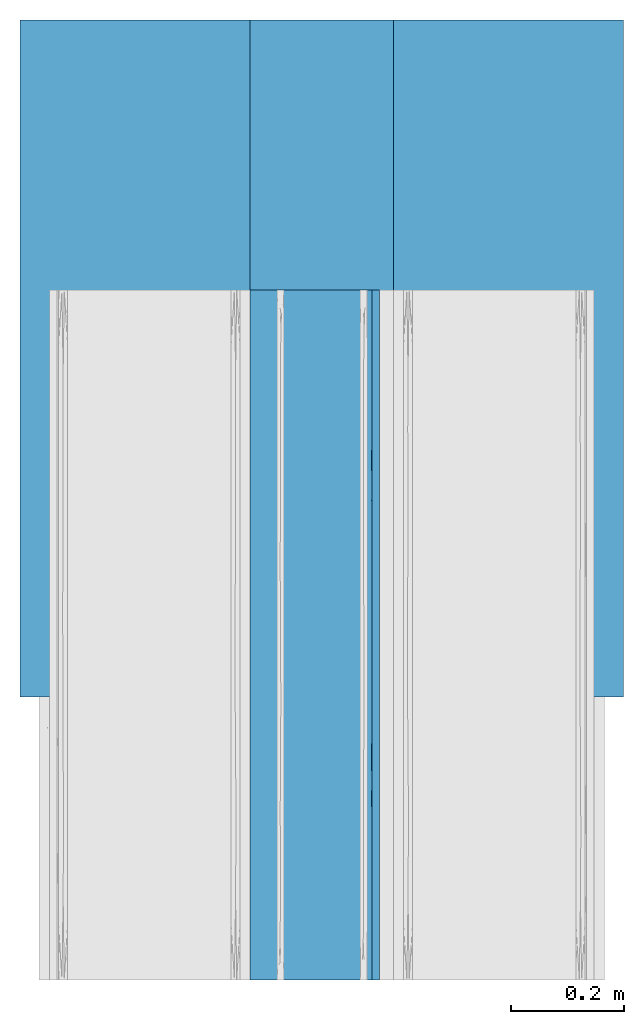
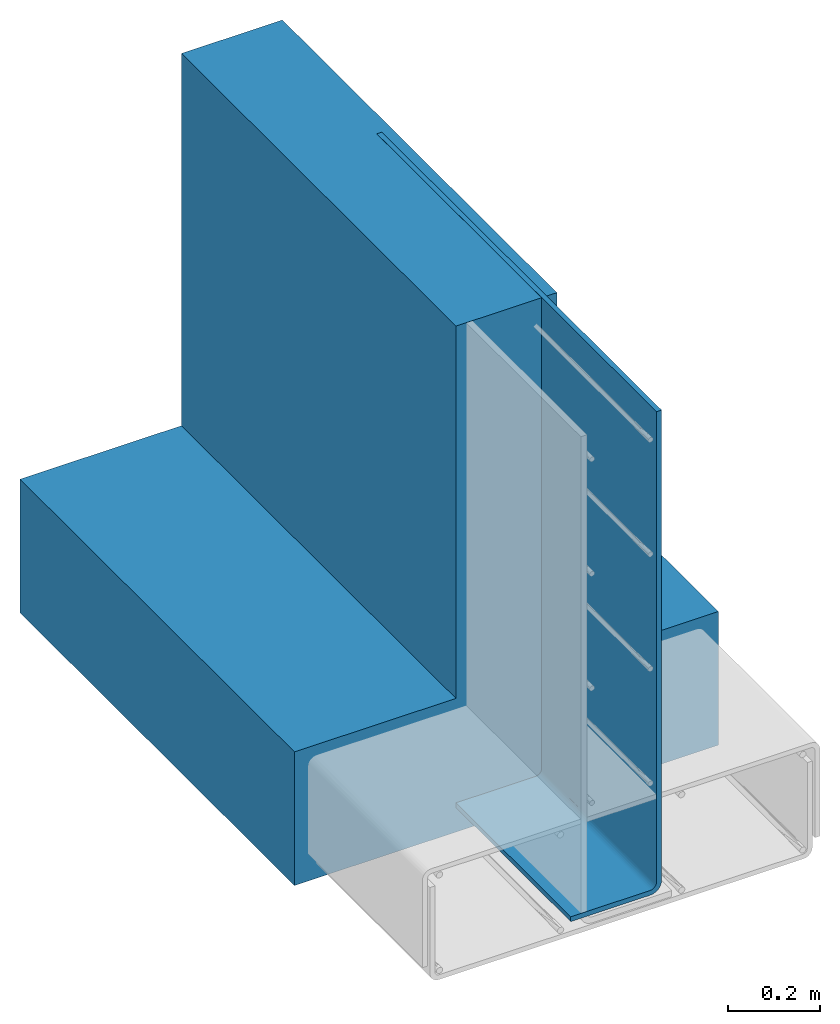
# One storey, part 1 of 10: 2 walls.
"""IFC2X3 building model written with IfcOpenShell, lengths in feet."""

from ifc_helpers import new_model, entity, si_unit, converted_unit, derived_unit, direction, frame, origin, place, context, subcontext, project, spatial, faceted_brep, material, type_object, element, save


model = new_model("IFC2X3")

# Units and contexts
model_context = context("Model", 3, precision=0.0001, world=origin(), true_north=direction((6.12303176911189e-17, 1.0)))
body_context = subcontext(model_context, "Body", "Model", "MODEL_VIEW")
ifc_project = project(units=[converted_unit("LENGTHUNIT", "FOOT", entity("IfcRatioMeasure", 0.3048), si_unit("LENGTHUNIT", "METRE"), dimensions=[1, 0, 0, 0, 0, 0, 0]), converted_unit("AREAUNIT", "SQUARE FOOT", entity("IfcRatioMeasure", 0.09290304), si_unit("AREAUNIT", "SQUARE_METRE"), dimensions=[2, 0, 0, 0, 0, 0, 0]), converted_unit("VOLUMEUNIT", "CUBIC FOOT", entity("IfcRatioMeasure", 0.028316846592), si_unit("VOLUMEUNIT", "CUBIC_METRE"), dimensions=[3, 0, 0, 0, 0, 0, 0]), converted_unit("PLANEANGLEUNIT", "DEGREE", entity("IfcRatioMeasure", 0.0174532925199433), si_unit("PLANEANGLEUNIT", "RADIAN"), dimensions=[0, 0, 0, 0, 0, 0, 0]), si_unit("MASSUNIT", "GRAM", prefix="KILO"), derived_unit("MASSDENSITYUNIT", [(si_unit("MASSUNIT", "GRAM", prefix="KILO"), 1), (si_unit("LENGTHUNIT", "METRE"), -3)]), si_unit("TIMEUNIT", "SECOND"), si_unit("FREQUENCYUNIT", "HERTZ"), si_unit("THERMODYNAMICTEMPERATUREUNIT", "DEGREE_CELSIUS"), derived_unit("THERMALTRANSMITTANCEUNIT", [(si_unit("MASSUNIT", "GRAM", prefix="KILO"), 1), (si_unit("THERMODYNAMICTEMPERATUREUNIT", "KELVIN"), -1), (si_unit("TIMEUNIT", "SECOND"), -3)]), derived_unit("VOLUMETRICFLOWRATEUNIT", [(si_unit("LENGTHUNIT", "METRE"), 3), (si_unit("TIMEUNIT", "SECOND"), -1)]), si_unit("ELECTRICCURRENTUNIT", "AMPERE"), si_unit("ELECTRICVOLTAGEUNIT", "VOLT"), si_unit("POWERUNIT", "WATT"), si_unit("FORCEUNIT", "NEWTON", prefix="KILO"), si_unit("ILLUMINANCEUNIT", "LUX"), si_unit("LUMINOUSFLUXUNIT", "LUMEN"), si_unit("LUMINOUSINTENSITYUNIT", "CANDELA"), derived_unit("USERDEFINED", [(si_unit("MASSUNIT", "GRAM", prefix="KILO"), -1), (si_unit("LENGTHUNIT", "METRE"), -2), (si_unit("TIMEUNIT", "SECOND"), 3), (si_unit("LUMINOUSFLUXUNIT", "LUMEN"), 1)]), derived_unit("LINEARVELOCITYUNIT", [(si_unit("LENGTHUNIT", "METRE"), 1), (si_unit("TIMEUNIT", "SECOND"), -1)]), si_unit("PRESSUREUNIT", "PASCAL"), derived_unit("USERDEFINED", [(si_unit("LENGTHUNIT", "METRE"), -2), (si_unit("MASSUNIT", "GRAM", prefix="KILO"), 1), (si_unit("TIMEUNIT", "SECOND"), -2)])], contexts=[model_context])

# Site, building, storey
site_placement = place(None, origin())
site = spatial("IfcSite", under=ifc_project, at=site_placement, CompositionType="ELEMENT")
building_placement = place(site_placement, origin())
building = spatial("IfcBuilding", under=site, at=building_placement, CompositionType="ELEMENT")
storey_placement = place(building_placement, frame((0.0, 0.0, 11.2604166666667)))
storey = spatial("IfcBuildingStorey", under=building, at=storey_placement, Name="2ND FLOOR", CompositionType="ELEMENT", Elevation=11.2604166666667)

# Walls
ifc_material_1 = material()
wall_type_1 = type_object("IfcWallType", Name="Generic Models 1", PredefinedType="NOTDEFINED", material=ifc_material_1)
wall_1_placement = place(storey_placement, frame((1427.92878869988, 1.89104784498346, 2.73836674408173), z_axis=(0.0, 0.0, 1.0), x_axis=(0.0, 1.0, 0.0)))
element("IfcWall", 1, at=wall_1_placement, inside=storey, type_object=wall_type_1, material=ifc_material_1, Name="Generic Models 42:Generic Models 1", ObjectType="Generic Models 42:Generic Models 1", context=body_context, shape_type="Brep", body=[
    faceted_brep([(3.92583335960777, -2.16666666666674, 1.16666666666667), (3.92583335960776, -3.5, 1.16666666666667), (3.92583335960776, -3.5, 0.0), (3.92583335960777, 0.0, 0.0), (3.92583335960777, 0.0, 1.16666666666668), (3.92583335960777, -1.33333333333326, 1.16666666666668), (3.92583335960778, -1.33333333333326, 4.41666666666668), (3.92583335960777, -2.16666666666674, 4.41666666666667), (0.0, -2.16666666666674, 1.16666666666668), (0.0, -2.16666666666674, 4.41666666666668), (0.0, -1.33333333333326, 4.41666666666669), (0.0, -1.33333333333326, 1.16666666666668), (0.0, 0.0, 1.16666666666669), (0.0, 0.0, 0.0), (0.0, -3.5, 0.0), (0.0, -3.5, 1.16666666666668)], [[[0, 1, 2, 3, 4, 5, 6, 7]], [[8, 9, 10, 11, 12, 13, 14, 15]], [[13, 12, 4, 3]], [[14, 13, 3, 2]], [[15, 14, 2, 1]], [[8, 15, 1, 0]], [[9, 8, 0, 7]], [[10, 9, 7, 6]], [[11, 10, 6, 5]], [[12, 11, 5, 4]]]),
])
ifc_material_2 = material()
wall_type_2 = type_object("IfcWallType", Name="Generic Models 1", PredefinedType="NOTDEFINED", material=ifc_material_2)
wall_2_placement = place(storey_placement, frame((1429.26212203322, 0.249999999995818, 2.95190841074831), z_axis=(0.0, 0.0, 1.0), x_axis=(0.0, 1.0, 0.0)))
element("IfcWall", 2, at=wall_2_placement, inside=storey, type_object=wall_type_2, material=ifc_material_2, Name="Generic Models 45:Generic Models 1", ObjectType="Generic Models 45:Generic Models 1", context=body_context, shape_type="Brep", body=[
    faceted_brep([(4.0, -0.654940473948045, 0.0), (4.0, 0.0, 0.0), (4.0, 0.0, 0.0416666666663001), (4.0, -0.654940473948045, 0.0416666666668739), (4.0, -0.668759562829564, 0.0434859842324968), (4.0, -0.681636903640765, 0.0488199534438305), (4.0, -0.692694926886361, 0.0573050731139269), (4.0, -0.701180046556601, 0.0683630963595885), (4.0, -0.70651401576788, 0.081240437170873), (4.0, -0.70833333333394, 0.0950595260523031), (4.0, -0.70833333333394, 4.2031250000001), (4.0, -0.750000000000227, 4.2031250000001), (4.0, -0.750000000000227, 0.0950595260523031), (4.0, -0.746760925196668, 0.0704563102916005), (4.0, -0.737264438380862, 0.0475297630262546), (4.0, -0.722157709435805, 0.027842290564486), (4.0, -0.702470236974023, 0.0127355616194791), (4.0, -0.67954368970868, 0.00323907480378516), (0.0, -0.70651401576788, 0.0812404371708659), (0.0, -0.701180046556601, 0.0683630963595814), (0.0, -0.692694926886361, 0.0573050731139197), (0.0, -0.681636903640765, 0.0488199534438234), (0.0, -0.668759562829564, 0.0434859842324897), (0.0, -0.654940473948045, 0.0416666666668668), (0.0, 0.0, 0.041666666666293), (0.0, 0.0, 0.0), (0.0, -0.654940473948045, 0.0), (0.0, -0.67954368970868, 0.00323907480377805), (0.0, -0.702470236974023, 0.012735561619472), (0.0, -0.722157709435805, 0.0278422905644788), (0.0, -0.737264438380862, 0.0475297630262475), (0.0, -0.746760925196668, 0.0704563102915934), (0.0, -0.750000000000227, 0.095059526052296), (0.0, -0.750000000000227, 4.20312500000009), (0.0, -0.70833333333394, 4.20312500000009), (0.0, -0.708333333333485, 0.095059526052296), (3.53786209601163, -0.708333333333485, 0.0950595260523031), (3.07572419202325, -0.708333333333485, 0.0950595260523013), (2.76893104800582, -0.708333333333485, 0.0950595260522995), (2.46213790398839, -0.708333333333485, 0.0950595260522995), (2.15534475997096, -0.708333333333485, 0.0950595260522995), (1.84855161595353, -0.708333333333485, 0.0950595260522995), (1.38641371196515, -0.708333333333485, 0.0950595260522995), (0.924275807976768, -0.708333333333485, 0.0950595260522977), (0.462137903988388, -0.708333333333485, 0.095059526052296), (0.616639049233824, -0.750000000000227, 0.0950595260522977), (1.23327809846764, -0.750000000000227, 0.0950595260522995), (1.84991714770146, -0.750000000000227, 0.0950595260522995), (2.46654337646354, -0.750000000000227, 0.0950595260522995), (3.23327168823178, -0.750000000000455, 0.0950595260523031), (3.50726805026566, -0.742764024438657, 0.0586818203459991), (3.27393777489857, -0.730356266470153, 0.0371909531347612), (1.78353021485442, -0.692743608241926, 0.00784005270600829), (2.14117387155801, -0.712809046871143, 0.0196437335345188), (1.43361804815222, -0.710409011264119, 0.0178613728279355), (3.37133042403174, -0.712809046871371, 0.0196437335345596), (3.47516629155208, -0.684714342549569, 0.00478311583486857), (1.16066371901762, -0.730356266491071, 0.0371909531619252), (1.64315400937903, -0.736469617346074, 0.0461789340957903), (1.27449515241569, -0.744572591547922, 0.0633988724297367), (3.20256950663317, -0.747872964695944, 0.0750628849187933), (0.766726281502993, -0.654940473948045, 0.0), (3.38336486871777, -0.654940473948045, 0.0), (2.76672973743553, -0.654940473948045, 0.0), (3.0750482505511, -0.672165363612976, 0.00157360909534354), (2.27636655078764, -0.677207509047321, 0.00264474021617644), (1.53345947487106, -0.654940473948045, 0.0), (0.914458128687511, -0.673697549752205, 0.0018689385419588), (0.924951748600551, -0.748367007938896, 0.0775154033977543), (2.89787096288552, -0.742764024439339, 0.0586818203472532), (0.726062224985724, -0.712809046889788, 0.0196437335487509), (1.47536976770805, -0.675630905083608, 0.00227903482341141), (2.1500946061533, -0.654940473948045, 0.0), (0.524941123283752, -0.730356266478793, 0.0371909531461316), (0.523544479078734, -0.688260808434279, 0.00603105418525907), (2.75625214777426, -0.710886029197582, 0.0182063651474849), (2.46098355502067, -0.731003860446435, 0.0380448373515279), (2.96682787454796, -0.691318179661494, 0.00723597556452482), (0.74650406804044, -0.742764024446615, 0.0586818203647752), (1.72599254344286, -0.724628522043304, 0.0304074615384167), (2.61939838620574, -0.747999034295844, 0.07565803540761), (1.82218751553688, -0.744542946883485, 0.0633150724093436), (1.10212903734058, -0.691318179697419, 0.00723597557942668), (2.37080233363285, -0.696497835331684, 0.00956508641982445), (2.35548845498682, -0.743252101924099, 0.0598832576675505), (0.462137772483759, -0.654940473948045, 0.0416666666668686), (0.924275704597117, -0.654940473948045, 0.0416666666668686), (1.38641363671048, -0.654940473948045, 0.0416666666668704), (1.84855156882383, -0.654940473948045, 0.0416666666668704), (2.1553446706538, -0.654940473948045, 0.0416666666668721), (2.46213793211337, -0.654940473948045, 0.0416666666668704), (2.76893119357294, -0.654940473948045, 0.0416666666668704), (3.0757242954029, -0.654940473948045, 0.0416666666668721), (3.53786222751626, -0.654940473948045, 0.0416666666668721), (3.64598811712504, -0.697299877144587, 0.0625560124856221), (1.94218582917246, -0.689093412479906, 0.0540183976201511), (1.7844557448637, -0.700799087499718, 0.067713868326214), (2.09940456529272, -0.699184866415408, 0.0651725528274447), (1.47460447533869, -0.702533590570511, 0.0708584375743069), (1.15534474637238, -0.705782492088247, 0.0787534957325668), (1.48739929718563, -0.706737282250288, 0.08210236266466), (0.63769039670443, -0.704269043902059, 0.0746269633239951), (0.414263127907032, -0.697299877262594, 0.0625560126393534), (0.287039221922981, -0.704269043910244, 0.0746269633438672), (3.58573686408363, -0.687443987216056, 0.0527001226265824), (0.46236480933283, -0.70712805056678, 0.0837788221728459), (3.36230959219967, -0.675373036542624, 0.0457309560429078), (2.91027129403529, -0.67529423467704, 0.0456983889347438), (3.1442828206046, -0.686932031455399, 0.052312155588119), (3.20329566014424, -0.665610566004943, 0.0427436912711396), (3.53763518372118, -0.666221177726129, 0.0428719494116319), (1.06747187120828, -0.686899893475356, 0.0522881227923335), (0.87330765656503, -0.675612061593483, 0.0458306432946163), (0.645037423284104, -0.687443987251754, 0.0527001226538975), (0.80093383662545, -0.698311267812414, 0.0639183688334466), (2.22079103365052, -0.688777997513398, 0.0537579591047699), (2.6833144259933, -0.689272242176457, 0.054167875025934), (2.46213789152936, -0.677182288721951, 0.0465198607370549), (0.29107500763931, -0.687443987293818, 0.0527001226862005), (3.6466666164122, -0.707137317158413, 0.0838217775129948), (3.75381505076288, -0.70409496819002, 0.0742116693479389), (3.71296077324106, -0.675373036583323, 0.0457309560597405), (3.32859635224714, -0.699184284103694, 0.0651716907968005), (2.9074547776396, -0.664096162172882, 0.0424575222265879), (2.6155344681911, -0.666323046289108, 0.0428940731140681), (0.796704327672058, -0.707256308704473, 0.0843894338746161), (0.416849823803879, -0.675373036577412, 0.0457309560573353), (2.60225741992453, -0.704500195142373, 0.0751941927176265), (2.31326743691376, -0.70586224472504, 0.0790042872096333), (2.61553444643094, -0.707492782959434, 0.0856227760337589), (1.32784821439839, -0.676962339802003, 0.0464196775979406), (3.30679310827372, -0.707491903927348, 0.0856178821016425), (3.14757123404816, -0.703347670118546, 0.0725308600405103), (2.89992805880822, -0.705601455777924, 0.0781994443978817), (0.3104121269, -0.665027413329653, 0.0426281319523643), (1.12933184833539, -0.666136511478271, 0.0428537200823094), (0.811192008238723, -0.66523545261748, 0.0426685836333291), (2.1621734149421, -0.679919010069852, 0.0478698008298988), (3.44406569779068, -0.704269043676504, 0.0746269627796643), (2.56192795606219, -0.699541086891259, 0.0657067960525985), (1.81115138144312, -0.705519689828634, 0.0779557149492121), (3.01120459260311, -0.697299877075011, 0.0625560123948858), (2.20626680044722, -0.665951770188258, 0.04281444218344), (1.18760454552437, -0.697299877202568, 0.0625560125612346), (1.75986133782446, -0.683162484460354, 0.0497349680732277), (1.67497245290147, -0.691173304635186, 0.0558424454146014), (1.47980629766405, -0.666577214964946, 0.0429501824385063), (1.9111713378428, -0.664941043478848, 0.0426115895589483), (1.3955252457092, -0.6865651152998, 0.0520400014997673), (1.60857290622061, -0.675061831460653, 0.0456031977898874), (1.89543238866513, -0.674789727278949, 0.045493362436817), (1.55304368584786, -0.697352793377604, 0.0626250907410135)], [[[0, 1, 2, 3, 4, 5, 6, 7, 8, 9, 10, 11, 12, 13, 14, 15, 16, 17]], [[18, 19, 20, 21, 22, 23, 24, 25, 26, 27, 28, 29, 30, 31, 32, 33, 34, 35]], [[35, 34, 10, 9, 36, 37, 38, 39, 40, 41, 42, 43, 44]], [[34, 33, 11, 10]], [[33, 32, 45, 46, 47, 48, 49, 12, 11]], [[50, 51, 14]], [[52, 53, 54]], [[14, 51, 15]], [[14, 13, 50]], [[55, 16, 15]], [[16, 55, 56]], [[57, 58, 59]], [[49, 60, 12]], [[27, 26, 61]], [[62, 0, 17]], [[63, 64, 65]], [[66, 67, 61]], [[31, 68, 45]], [[60, 69, 50]], [[54, 57, 70]], [[71, 72, 65]], [[29, 73, 30]], [[70, 28, 74]], [[53, 75, 76]], [[64, 56, 77]], [[68, 31, 78]], [[30, 73, 78]], [[55, 15, 51]], [[30, 78, 31]], [[67, 74, 27]], [[59, 46, 68]], [[28, 70, 29]], [[79, 57, 54]], [[62, 64, 63]], [[80, 69, 60]], [[81, 47, 59]], [[54, 70, 82]], [[67, 66, 71]], [[73, 70, 57]], [[76, 51, 69]], [[49, 80, 60]], [[53, 83, 75]], [[80, 84, 69]], [[79, 58, 57]], [[51, 76, 75]], [[56, 55, 77]], [[45, 68, 46]], [[45, 32, 31]], [[59, 68, 78]], [[56, 62, 17]], [[65, 64, 77]], [[52, 83, 53]], [[65, 52, 71]], [[62, 56, 64]], [[16, 56, 17]], [[57, 59, 78]], [[80, 47, 81]], [[70, 73, 29]], [[78, 73, 57]], [[51, 50, 69]], [[52, 54, 82]], [[54, 53, 79]], [[71, 52, 82]], [[52, 65, 83]], [[71, 82, 67]], [[74, 67, 82]], [[27, 61, 67]], [[70, 74, 82]], [[28, 27, 74]], [[65, 77, 83]], [[75, 77, 55]], [[77, 75, 83]], [[75, 55, 51]], [[53, 76, 79]], [[76, 84, 58]], [[76, 58, 79]], [[59, 58, 81]], [[13, 12, 60]], [[13, 60, 50]], [[80, 49, 48, 47]], [[72, 71, 66]], [[84, 80, 81]], [[58, 84, 81]], [[76, 69, 84]], [[46, 59, 47]], [[72, 63, 65]], [[25, 1, 0, 62, 63, 72, 66, 61, 26]], [[24, 23, 85, 86, 87, 88, 89, 90, 91, 92, 93, 3, 2]], [[94, 7, 6]], [[95, 96, 97]], [[98, 99, 100]], [[101, 102, 103]], [[104, 94, 6]], [[18, 105, 103]], [[106, 107, 108]], [[109, 110, 93]], [[111, 112, 113]], [[102, 101, 114]], [[6, 5, 104]], [[115, 116, 117]], [[21, 20, 118]], [[119, 36, 9]], [[119, 8, 120]], [[104, 121, 106]], [[122, 104, 108]], [[18, 103, 19]], [[123, 91, 124]], [[5, 4, 121]], [[4, 110, 121]], [[125, 105, 44]], [[126, 22, 21]], [[127, 128, 129]], [[113, 112, 126]], [[112, 111, 130]], [[102, 20, 19]], [[125, 44, 43]], [[119, 131, 36]], [[132, 133, 131]], [[106, 108, 104]], [[107, 117, 116]], [[126, 118, 113]], [[134, 85, 23]], [[3, 110, 4]], [[104, 122, 94]], [[112, 135, 136]], [[117, 137, 115]], [[20, 102, 118]], [[35, 105, 18]], [[114, 111, 113]], [[126, 134, 22]], [[135, 86, 136]], [[7, 94, 120]], [[36, 131, 37]], [[138, 94, 122]], [[97, 139, 115]], [[128, 97, 140]], [[136, 134, 126]], [[130, 135, 112]], [[141, 108, 116]], [[107, 116, 108]], [[141, 116, 139]], [[115, 139, 116]], [[142, 124, 90]], [[93, 92, 109]], [[139, 133, 141]], [[123, 124, 107]], [[139, 97, 128]], [[132, 122, 141]], [[40, 128, 140]], [[129, 39, 38]], [[139, 128, 127]], [[128, 39, 129]], [[99, 43, 42]], [[140, 97, 96]], [[100, 42, 41]], [[101, 99, 114]], [[143, 99, 98]], [[140, 96, 98]], [[95, 144, 145]], [[135, 130, 146]], [[142, 89, 147]], [[111, 143, 148]], [[148, 144, 149]], [[130, 111, 148]], [[143, 111, 114]], [[21, 118, 126]], [[113, 118, 102]], [[5, 121, 104]], [[106, 121, 110]], [[109, 106, 110]], [[3, 93, 110]], [[109, 107, 106]], [[117, 107, 124]], [[90, 124, 91]], [[92, 123, 109]], [[142, 137, 117]], [[124, 142, 117]], [[150, 142, 147]], [[19, 103, 102]], [[101, 103, 105]], [[125, 101, 105]], [[35, 44, 105]], [[125, 99, 101]], [[125, 43, 99]], [[102, 114, 113]], [[143, 114, 99]], [[135, 87, 86]], [[146, 147, 88]], [[87, 135, 146]], [[87, 146, 88]], [[146, 130, 149]], [[112, 136, 126]], [[136, 86, 85]], [[91, 123, 92]], [[109, 123, 107]], [[146, 149, 147]], [[150, 149, 144]], [[144, 95, 137]], [[148, 145, 144]], [[150, 144, 137]], [[115, 95, 97]], [[37, 131, 133]], [[138, 131, 119]], [[138, 119, 120]], [[8, 119, 9]], [[138, 120, 94]], [[7, 120, 8]], [[22, 134, 23]], [[85, 134, 136]], [[138, 122, 132]], [[141, 122, 108]], [[138, 132, 131]], [[133, 132, 141]], [[38, 37, 133]], [[127, 133, 139]], [[129, 38, 133]], [[41, 40, 140]], [[127, 129, 133]], [[40, 39, 128]], [[145, 151, 96]], [[140, 98, 100]], [[140, 100, 41]], [[100, 99, 42]], [[98, 96, 151]], [[145, 96, 95]], [[151, 143, 98]], [[143, 151, 148]], [[115, 137, 95]], [[150, 137, 142]], [[149, 130, 148]], [[151, 145, 148]], [[149, 150, 147]], [[88, 147, 89]], [[142, 90, 89]], [[25, 24, 2, 1]]]),
])

save(model, "model.ifc")
